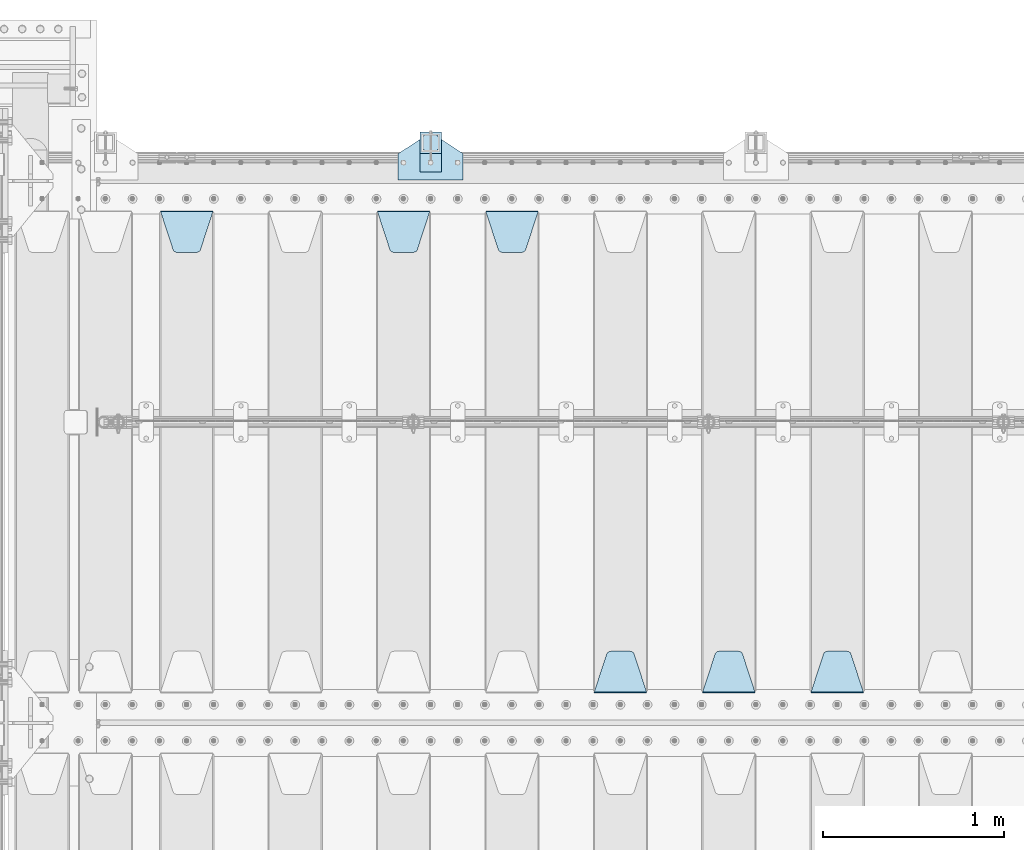
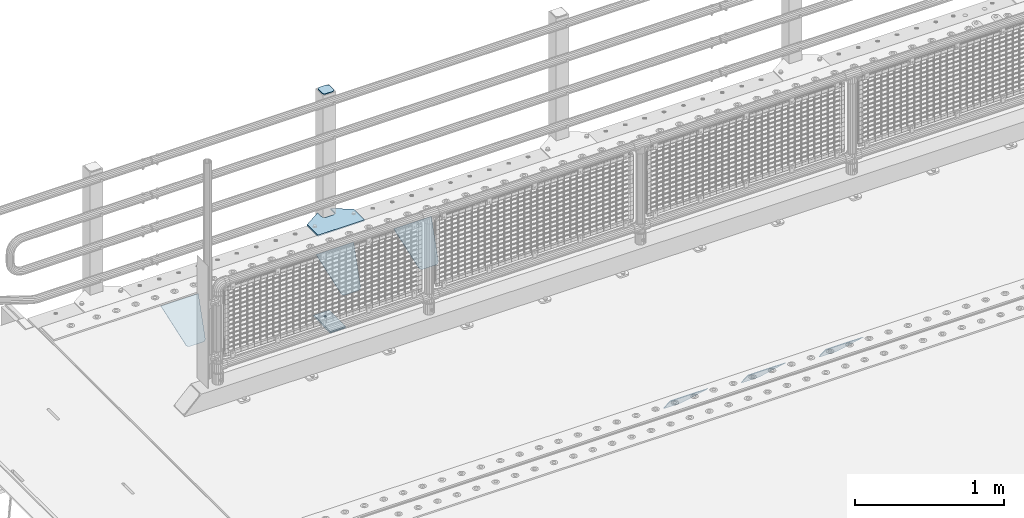
# One storey, part 201 of 242: 10 plates.
"""IFC2X3 building model written with IfcOpenShell, lengths in millimetres."""

from ifc_helpers import new_model, si_unit, frame, origin_with_axes, place, context, subcontext, project, spatial, faceted_brep, material, type_object, element, save


model = new_model("IFC2X3")

# Units and contexts
model_context = context("Model", 3, precision=1e-05, world=origin_with_axes())
body_context = subcontext(model_context, "Body", "Model", "MODEL_VIEW")
ifc_project = project(units=[si_unit("LENGTHUNIT", "METRE", prefix="MILLI"), si_unit("AREAUNIT", "SQUARE_METRE"), si_unit("VOLUMEUNIT", "CUBIC_METRE"), si_unit("MASSUNIT", "GRAM", prefix="KILO"), si_unit("TIMEUNIT", "SECOND"), si_unit("PLANEANGLEUNIT", "RADIAN"), si_unit("SOLIDANGLEUNIT", "STERADIAN"), si_unit("THERMODYNAMICTEMPERATUREUNIT", "DEGREE_CELSIUS"), si_unit("LUMINOUSINTENSITYUNIT", "LUMEN")], contexts=[model_context])

# Site, building, storey
site_placement = place(None, origin_with_axes())
site = spatial("IfcSite", under=ifc_project, at=site_placement, CompositionType="ELEMENT")
building_placement = place(site_placement, origin_with_axes())
building = spatial("IfcBuilding", under=site, at=building_placement, Name="Standard", CompositionType="ELEMENT")
storey_placement = place(building_placement, origin_with_axes())
storey = spatial("IfcBuildingStorey", under=building, at=storey_placement, Name="Undefined", CompositionType="ELEMENT", Elevation=0.0)

# Plates
ifc_material_1 = material(Name="STEEL/S355J2")
plate_type_1 = type_object("IfcPlateType", PredefinedType="NOTDEFINED")
plate_1_placement = place(storey_placement, frame((-40280.0, -17995.0, 5.00000000004911), z_axis=(0.0, 1.0, 0.0), x_axis=(1.0, 0.0, 0.0)))
element("IfcPlate", 1, at=plate_1_placement, inside=storey, type_object=plate_type_1, material=ifc_material_1, context=body_context, shape_type="Brep", body=[
    faceted_brep([(0.0, -5.0, 0.0), (2.31396552408114e-06, -5.0, 145.0), (2.31396552408114e-06, 5.0, 145.0), (0.0, 5.0, 0.0), (130.0, -5.0, 230.0), (130.0, 5.0, 230.0), (130.0, -5.0, 180.0), (130.0, 5.0, 180.0), (130.48036798992, -5.0, 175.122741949595), (130.48036798992, 5.0, 175.122741949595), (131.903011687216, -5.0, 170.432914190871), (131.903011687216, 5.0, 170.432914190871), (134.213259692435, -5.0, 166.110744174512), (134.213259692435, 5.0, 166.110744174512), (137.322330470335, -5.0, 162.322330470335), (137.322330470335, 5.0, 162.322330470335), (141.110744174512, -5.0, 159.213259692435), (141.110744174512, 5.0, 159.213259692435), (145.432914190871, -5.0, 156.903011687216), (145.432914190871, 5.0, 156.903011687216), (150.122741949595, -5.0, 155.48036798992), (150.122741949595, 5.0, 155.48036798992), (155.0, -5.0, 155.0), (155.0, 5.0, 155.0), (205.0, -5.0, 155.0), (205.0, 5.0, 155.0), (209.877258050405, -5.0, 155.48036798992), (209.877258050405, 5.0, 155.48036798992), (214.567085809129, -5.0, 156.903011687216), (214.567085809129, 5.0, 156.903011687216), (218.889255825488, -5.0, 159.213259692435), (218.889255825488, 5.0, 159.213259692435), (222.677669529665, -5.0, 162.322330470335), (222.677669529665, 5.0, 162.322330470335), (225.786740307565, -5.0, 166.110744174512), (225.786740307565, 5.0, 166.110744174512), (228.096988312784, -5.0, 170.432914190871), (228.096988312784, 5.0, 170.432914190871), (229.51963201008, -5.0, 175.122741949595), (229.51963201008, 5.0, 175.122741949595), (230.0, -5.0, 180.0), (230.0, 5.0, 180.0), (230.0, -5.0, 230.0), (230.0, 5.0, 230.0), (360.0, -5.0, 145.0), (360.0, 5.0, 145.0), (360.0, -5.0, -7.27595761418343e-12), (360.0, 5.0, -7.27595761418343e-12)], [[[0, 1, 2, 3]], [[1, 4, 5, 2]], [[4, 6, 7, 5]], [[6, 8, 9, 7]], [[8, 10, 11, 9]], [[10, 12, 13, 11]], [[12, 14, 15, 13]], [[14, 16, 17, 15]], [[16, 18, 19, 17]], [[18, 20, 21, 19]], [[20, 22, 23, 21]], [[22, 24, 25, 23]], [[24, 26, 27, 25]], [[26, 28, 29, 27]], [[28, 30, 31, 29]], [[30, 32, 33, 31]], [[32, 34, 35, 33]], [[34, 36, 37, 35]], [[36, 38, 39, 37]], [[38, 40, 41, 39]], [[40, 42, 43, 41]], [[42, 44, 45, 43]], [[44, 46, 47, 45]], [[46, 0, 3, 47]], [[5, 7, 9, 11, 13, 15, 17, 19, 21, 23, 25, 27, 29, 31, 33, 35, 37, 39, 41, 43, 45, 47, 3, 2]], [[46, 44, 42, 40, 38, 36, 34, 32, 30, 28, 26, 24, 22, 20, 18, 16, 14, 12, 10, 8, 6, 4, 1, 0]]]),
])
plate_type_2 = type_object("IfcPlateType", PredefinedType="NOTDEFINED")
plate_2_placement = place(storey_placement, frame((-40159.9999999999, -17949.9999999998, -850.000000000002), z_axis=(0.0, 1.0, 0.0), x_axis=(1.0, 0.0, 0.0)))
element("IfcPlate", 2, at=plate_2_placement, inside=storey, type_object=plate_type_2, material=ifc_material_1, context=body_context, shape_type="Brep", body=[
    faceted_brep([(66.3639610305399, -5.0, 163.636038969114), (66.3639610305399, 5.0, 163.636038969114), (59.9999999998618, 5.0, 160.999999999793), (59.9999999998618, -5.0, 160.999999999793), (53.6360389691836, 5.0, 163.636038969114), (53.6360389691836, -5.0, 163.636038969114), (50.9999999998618, 5.0, 169.999999999793), (50.9999999998618, -5.0, 169.999999999793), (53.6360389691836, 5.0, 176.363961030471), (53.6360389691836, -5.0, 176.363961030471), (59.9999999998618, 5.0, 178.999999999793), (59.9999999998618, -5.0, 178.999999999793), (66.3639610305399, 5.0, 176.363961030471), (66.3639610305399, -5.0, 176.363961030471), (68.9999999998618, 5.0, 169.999999999793), (68.9999999998618, -5.0, 169.999999999793), (120.0, -5.0, 0.0), (120.0, -5.0, 220.0), (0.0, -5.0, 220.0), (0.0, -5.0, 0.0), (0.0, 5.0, 0.0), (120.0, 5.0, 0.0), (120.0, 5.0, 220.0), (0.0, 5.0, 220.0)], [[[0, 1, 2, 3]], [[3, 2, 4, 5]], [[5, 4, 6, 7]], [[7, 6, 8, 9]], [[9, 8, 10, 11]], [[11, 10, 12, 13]], [[13, 12, 14, 15]], [[15, 14, 1, 0]], [[16, 17, 18, 19], [11, 13, 15, 0, 3, 5, 7, 9]], [[16, 19, 20, 21]], [[17, 16, 21, 22]], [[18, 17, 22, 23]], [[19, 18, 23, 20]], [[22, 21, 20, 23], [2, 1, 14, 12, 10, 8, 6, 4]]]),
])
plate_type_3 = type_object("IfcPlateType", PredefinedType="NOTDEFINED")
plate_3_placement = place(storey_placement, frame((-40055.9999999999, -17833.9999999998, 1012.50000000001), z_axis=(0.0, 1.0, 0.0), x_axis=(-1.0, 0.0, 0.0)))
element("IfcPlate", 3, at=plate_3_placement, inside=storey, type_object=plate_type_3, material=ifc_material_1, context=body_context, shape_type="Brep", body=[
    faceted_brep([(0.0, -2.5, 19.0), (0.0, -2.5, 69.0), (0.0, 2.5, 69.0), (0.0, 2.5, 19.0), (0.476369668544066, -2.5, 73.2278977451715), (0.476369668544066, 2.5, 73.2278977451715), (1.88159150985302, -2.5, 77.2437910432345), (1.88159150985302, 2.5, 77.2437910432345), (4.14520183310742, -2.5, 80.8463062353148), (4.14520183310742, 2.5, 80.8463062353148), (7.15369376468516, -2.5, 83.8547981668926), (7.15369376468516, 2.5, 83.8547981668926), (10.7562089567655, -2.5, 86.118408490147), (10.7562089567655, 2.5, 86.118408490147), (14.7721022548285, -2.5, 87.5236303314559), (14.7721022548285, 2.5, 87.5236303314559), (19.0, -2.5, 88.0), (19.0, 2.5, 88.0), (69.0, -2.5, 88.0), (69.0, 2.5, 88.0), (73.2278977451715, -2.5, 87.5236303314559), (73.2278977451715, 2.5, 87.5236303314559), (77.2437910432345, -2.5, 86.118408490147), (77.2437910432345, 2.5, 86.118408490147), (80.8463062353148, -2.5, 83.8547981668926), (80.8463062353148, 2.5, 83.8547981668926), (83.8547981668926, -2.5, 80.8463062353148), (83.8547981668926, 2.5, 80.8463062353148), (86.118408490147, -2.5, 77.2437910432345), (86.118408490147, 2.5, 77.2437910432345), (87.5236303314559, -2.5, 73.2278977451715), (87.5236303314559, 2.5, 73.2278977451715), (88.0, -2.5, 69.0), (88.0, 2.5, 69.0), (88.0, -2.5, 19.0), (88.0, 2.5, 19.0), (87.5236303314559, -2.5, 14.7721022548285), (87.5236303314559, 2.5, 14.7721022548285), (86.118408490147, -2.5, 10.7562089567655), (86.118408490147, 2.5, 10.7562089567655), (83.8547981668926, -2.5, 7.15369376468516), (83.8547981668926, 2.5, 7.15369376468516), (80.8463062353148, -2.5, 4.14520183310742), (80.8463062353148, 2.5, 4.14520183310742), (77.2437910432345, -2.5, 1.88159150985302), (77.2437910432345, 2.5, 1.88159150985302), (73.2278977451715, -2.5, 0.476369668544066), (73.2278977451715, 2.5, 0.476369668544066), (69.0, -2.5, 0.0), (69.0, 2.5, 0.0), (19.0, -2.5, 0.0), (19.0, 2.5, 0.0), (14.7721022548285, -2.5, 0.476369668544066), (14.7721022548285, 2.5, 0.476369668544066), (10.7562089567655, -2.5, 1.88159150985302), (10.7562089567655, 2.5, 1.88159150985302), (7.15369376468516, -2.5, 4.14520183310742), (7.15369376468516, 2.5, 4.14520183310742), (4.14520183310742, -2.5, 7.15369376468516), (4.14520183310742, 2.5, 7.15369376468516), (1.88159150985302, -2.5, 10.7562089567655), (1.88159150985302, 2.5, 10.7562089567655), (0.476369668544066, -2.5, 14.7721022548285), (0.476369668544066, 2.5, 14.7721022548285)], [[[0, 1, 2, 3]], [[1, 4, 5, 2]], [[4, 6, 7, 5]], [[6, 8, 9, 7]], [[8, 10, 11, 9]], [[10, 12, 13, 11]], [[12, 14, 15, 13]], [[14, 16, 17, 15]], [[16, 18, 19, 17]], [[18, 20, 21, 19]], [[20, 22, 23, 21]], [[22, 24, 25, 23]], [[24, 26, 27, 25]], [[26, 28, 29, 27]], [[28, 30, 31, 29]], [[30, 32, 33, 31]], [[32, 34, 35, 33]], [[34, 36, 37, 35]], [[36, 38, 39, 37]], [[38, 40, 41, 39]], [[40, 42, 43, 41]], [[42, 44, 45, 43]], [[44, 46, 47, 45]], [[46, 48, 49, 47]], [[48, 50, 51, 49]], [[50, 52, 53, 51]], [[52, 54, 55, 53]], [[54, 56, 57, 55]], [[56, 58, 59, 57]], [[58, 60, 61, 59]], [[60, 62, 63, 61]], [[62, 0, 3, 63]], [[5, 7, 9, 11, 13, 15, 17, 19, 21, 23, 25, 27, 29, 31, 33, 35, 37, 39, 41, 43, 45, 47, 49, 51, 53, 55, 57, 59, 61, 63, 3, 2]], [[62, 60, 58, 56, 54, 52, 50, 48, 46, 44, 42, 40, 38, 36, 34, 32, 30, 28, 26, 24, 22, 20, 18, 16, 14, 12, 10, 8, 6, 4, 1, 0]]]),
])
plate_type_4 = type_object("IfcPlateType", PredefinedType="NOTDEFINED")
plate_4_placement = place(storey_placement, frame((-40159.9999999999, -17949.9999999998, -857.500000000002), z_axis=(0.0, 1.0, 0.0), x_axis=(1.0, 0.0, 0.0)))
element("IfcPlate", 4, at=plate_4_placement, inside=storey, type_object=plate_type_4, material=ifc_material_1, context=body_context, shape_type="Brep", body=[
    faceted_brep([(0.0, -2.5, 0.0), (0.0, -2.5, 100.0), (0.0, 2.5, 100.0), (0.0, 2.5, 0.0), (120.0, -2.5, 100.0), (120.0, 2.5, 100.0), (120.0, -2.5, 0.0), (120.0, 2.5, 0.0)], [[[0, 1, 2, 3]], [[1, 4, 5, 2]], [[4, 6, 7, 5]], [[6, 0, 3, 7]], [[5, 7, 3, 2]], [[6, 4, 1, 0]]]),
])
ifc_material_2 = material(Name="STEEL/S355N")
plate_type_5 = type_object("IfcPlateType", PredefinedType="NOTDEFINED")
plate_5_placement = place(storey_placement, frame((-37705.0, -20831.767766953, -1.76776695296758), z_axis=(0.0, 0.707106781186547, -0.707106781186548), x_axis=(-1.0, 0.0, 0.0)))
element("IfcPlate", 5, at=plate_5_placement, inside=storey, type_object=plate_type_5, material=ifc_material_2, context=body_context, shape_type="Brep", body=[
    faceted_brep([(0.0, -2.5, 0.0), (69.345504679477, -2.50000000000182, 300.171731424829), (69.345504679477, 2.5, 300.171731424829), (0.0, 2.5, 0.0), (70.9274061199576, -2.5, 304.897442415398), (70.9274061199576, 2.5, 304.897442415398), (73.3818627772307, -2.5, 309.234538108525), (73.3818627772307, 2.50000000000182, 309.234538108529), (76.6187032999551, -2.5, 313.023683126101), (76.6187032999551, 2.50000000000182, 313.023683126103), (80.5190132704993, -2.5, 316.12567259537), (80.5190132704993, 2.5, 316.12567259537), (84.9395038596849, -2.5, 318.426546230474), (84.9395038596849, 2.50000000000182, 318.426546230476), (89.7177759439219, -2.49999999999818, 319.841774983273), (89.7177759439219, 2.50000000000182, 319.841774983273), (94.678286292652, -2.5, 320.319366455076), (94.678286292652, 2.5, 320.319366455076), (195.321713707348, -2.5, 320.319366455076), (195.321713707348, 2.5, 320.319366455076), (200.282224056078, -2.5, 319.841774983272), (200.282224056078, 2.50000000000182, 319.841774983273), (205.060496140315, -2.5, 318.426546230474), (205.060496140315, 2.49999999999818, 318.426546230474), (209.480986729501, -2.49999999999818, 316.12567259537), (209.480986729501, 2.5, 316.12567259537), (213.381296700045, -2.5, 313.023683126101), (213.381296700045, 2.49999999999818, 313.023683126101), (216.618137222769, -2.5, 309.234538108525), (216.618137222769, 2.5, 309.234538108523), (219.072593880042, -2.49999999999818, 304.897442415398), (219.072593880042, 2.50000000000182, 304.897442415398), (220.654495320523, -2.50000000000182, 300.171731424829), (220.654495320523, 2.5, 300.171731424829), (290.0, -2.5, 0.0), (290.0, 2.5, -1.81898940354586e-12)], [[[0, 1, 2, 3]], [[1, 4, 5, 2]], [[4, 6, 7, 5]], [[6, 8, 9, 7]], [[8, 10, 11, 9]], [[10, 12, 13, 11]], [[12, 14, 15, 13]], [[14, 16, 17, 15]], [[16, 18, 19, 17]], [[18, 20, 21, 19]], [[20, 22, 23, 21]], [[22, 24, 25, 23]], [[24, 26, 27, 25]], [[26, 28, 29, 27]], [[28, 30, 31, 29]], [[30, 32, 33, 31]], [[32, 34, 35, 33]], [[34, 0, 3, 35]], [[5, 7, 9, 11, 13, 15, 17, 19, 21, 23, 25, 27, 29, 31, 33, 35, 3, 2]], [[34, 32, 30, 28, 26, 24, 22, 20, 18, 16, 14, 12, 10, 8, 6, 4, 1, 0]]]),
])
plate_6_placement = place(storey_placement, frame((-38305.0, -20831.767766953, -1.76776695296758), z_axis=(0.0, 0.707106781186547, -0.707106781186548), x_axis=(-1.0, 0.0, 0.0)))
element("IfcPlate", 6, at=plate_6_placement, inside=storey, type_object=plate_type_5, material=ifc_material_2, context=body_context, shape_type="Brep", body=[
    faceted_brep([(0.0, -2.5, 0.0), (69.345504679477, -2.50000000000182, 300.171731424829), (69.345504679477, 2.5, 300.171731424829), (0.0, 2.5, 0.0), (70.9274061199576, -2.5, 304.897442415398), (70.9274061199576, 2.5, 304.897442415398), (73.3818627772307, -2.5, 309.234538108525), (73.3818627772307, 2.50000000000182, 309.234538108529), (76.6187032999551, -2.5, 313.023683126101), (76.6187032999551, 2.50000000000182, 313.023683126103), (80.5190132704993, -2.5, 316.12567259537), (80.5190132704993, 2.5, 316.12567259537), (84.9395038596849, -2.5, 318.426546230474), (84.9395038596849, 2.50000000000182, 318.426546230476), (89.7177759439219, -2.49999999999818, 319.841774983273), (89.7177759439219, 2.50000000000182, 319.841774983273), (94.678286292652, -2.5, 320.319366455076), (94.678286292652, 2.5, 320.319366455076), (195.321713707348, -2.5, 320.319366455076), (195.321713707348, 2.5, 320.319366455076), (200.282224056078, -2.5, 319.841774983272), (200.282224056078, 2.50000000000182, 319.841774983273), (205.060496140315, -2.5, 318.426546230474), (205.060496140315, 2.49999999999818, 318.426546230474), (209.480986729501, -2.49999999999818, 316.12567259537), (209.480986729501, 2.5, 316.12567259537), (213.381296700045, -2.5, 313.023683126101), (213.381296700045, 2.49999999999818, 313.023683126101), (216.618137222769, -2.5, 309.234538108525), (216.618137222769, 2.5, 309.234538108523), (219.072593880042, -2.49999999999818, 304.897442415398), (219.072593880042, 2.50000000000182, 304.897442415398), (220.654495320523, -2.50000000000182, 300.171731424829), (220.654495320523, 2.5, 300.171731424829), (290.0, -2.5, 0.0), (290.0, 2.5, -1.81898940354586e-12)], [[[0, 1, 2, 3]], [[1, 4, 5, 2]], [[4, 6, 7, 5]], [[6, 8, 9, 7]], [[8, 10, 11, 9]], [[10, 12, 13, 11]], [[12, 14, 15, 13]], [[14, 16, 17, 15]], [[16, 18, 19, 17]], [[18, 20, 21, 19]], [[20, 22, 23, 21]], [[22, 24, 25, 23]], [[24, 26, 27, 25]], [[26, 28, 29, 27]], [[28, 30, 31, 29]], [[30, 32, 33, 31]], [[32, 34, 35, 33]], [[34, 0, 3, 35]], [[5, 7, 9, 11, 13, 15, 17, 19, 21, 23, 25, 27, 29, 31, 33, 35, 3, 2]], [[34, 32, 30, 28, 26, 24, 22, 20, 18, 16, 14, 12, 10, 8, 6, 4, 1, 0]]]),
])
plate_7_placement = place(storey_placement, frame((-38905.0, -20831.767766953, -1.76776695296758), z_axis=(0.0, 0.707106781186547, -0.707106781186548), x_axis=(-1.0, 0.0, 0.0)))
element("IfcPlate", 7, at=plate_7_placement, inside=storey, type_object=plate_type_5, material=ifc_material_2, context=body_context, shape_type="Brep", body=[
    faceted_brep([(0.0, -2.5, 0.0), (69.345504679477, -2.50000000000182, 300.171731424829), (69.345504679477, 2.5, 300.171731424829), (0.0, 2.5, 0.0), (70.9274061199576, -2.5, 304.897442415398), (70.9274061199576, 2.5, 304.897442415398), (73.3818627772307, -2.5, 309.234538108525), (73.3818627772307, 2.50000000000182, 309.234538108529), (76.6187032999551, -2.5, 313.023683126101), (76.6187032999551, 2.50000000000182, 313.023683126103), (80.5190132704993, -2.5, 316.12567259537), (80.5190132704993, 2.5, 316.12567259537), (84.9395038596849, -2.5, 318.426546230474), (84.9395038596849, 2.50000000000182, 318.426546230476), (89.7177759439219, -2.49999999999818, 319.841774983273), (89.7177759439219, 2.50000000000182, 319.841774983273), (94.678286292652, -2.5, 320.319366455076), (94.678286292652, 2.5, 320.319366455076), (195.321713707348, -2.5, 320.319366455076), (195.321713707348, 2.5, 320.319366455076), (200.282224056078, -2.5, 319.841774983272), (200.282224056078, 2.50000000000182, 319.841774983273), (205.060496140315, -2.5, 318.426546230474), (205.060496140315, 2.49999999999818, 318.426546230474), (209.480986729501, -2.49999999999818, 316.12567259537), (209.480986729501, 2.5, 316.12567259537), (213.381296700045, -2.5, 313.023683126101), (213.381296700045, 2.49999999999818, 313.023683126101), (216.618137222769, -2.5, 309.234538108525), (216.618137222769, 2.5, 309.234538108523), (219.072593880042, -2.49999999999818, 304.897442415398), (219.072593880042, 2.50000000000182, 304.897442415398), (220.654495320523, -2.50000000000182, 300.171731424829), (220.654495320523, 2.5, 300.171731424829), (290.0, -2.5, 0.0), (290.0, 2.5, -1.81898940354586e-12)], [[[0, 1, 2, 3]], [[1, 4, 5, 2]], [[4, 6, 7, 5]], [[6, 8, 9, 7]], [[8, 10, 11, 9]], [[10, 12, 13, 11]], [[12, 14, 15, 13]], [[14, 16, 17, 15]], [[16, 18, 19, 17]], [[18, 20, 21, 19]], [[20, 22, 23, 21]], [[22, 24, 25, 23]], [[24, 26, 27, 25]], [[26, 28, 29, 27]], [[28, 30, 31, 29]], [[30, 32, 33, 31]], [[32, 34, 35, 33]], [[34, 0, 3, 35]], [[5, 7, 9, 11, 13, 15, 17, 19, 21, 23, 25, 27, 29, 31, 33, 35, 3, 2]], [[34, 32, 30, 28, 26, 24, 22, 20, 18, 16, 14, 12, 10, 8, 6, 4, 1, 0]]]),
])
plate_8_placement = place(storey_placement, frame((-39795.0, -18168.2322330441, -1.76776695296576), z_axis=(0.0, -0.707106781186547, -0.707106781186548), x_axis=(1.0, 0.0, 0.0)))
element("IfcPlate", 8, at=plate_8_placement, inside=storey, type_object=plate_type_5, material=ifc_material_2, context=body_context, shape_type="Brep", body=[
    faceted_brep([(0.0, -2.5, 0.0), (69.345504679477, -2.50000000000182, 300.171731424829), (69.345504679477, 2.5, 300.171731424829), (0.0, 2.5, 0.0), (70.9274061199576, -2.5, 304.897442415398), (70.9274061199576, 2.5, 304.897442415398), (73.3818627772307, -2.5, 309.234538108525), (73.3818627772307, 2.50000000000182, 309.234538108529), (76.6187032999551, -2.5, 313.023683126101), (76.6187032999551, 2.50000000000182, 313.023683126103), (80.5190132704993, -2.5, 316.12567259537), (80.5190132704993, 2.5, 316.12567259537), (84.9395038596849, -2.5, 318.426546230474), (84.9395038596849, 2.50000000000182, 318.426546230476), (89.7177759439219, -2.49999999999818, 319.841774983273), (89.7177759439219, 2.50000000000182, 319.841774983273), (94.678286292652, -2.5, 320.319366455076), (94.678286292652, 2.5, 320.319366455076), (195.321713707348, -2.5, 320.319366455076), (195.321713707348, 2.5, 320.319366455076), (200.282224056078, -2.5, 319.841774983272), (200.282224056078, 2.50000000000182, 319.841774983273), (205.060496140315, -2.5, 318.426546230474), (205.060496140315, 2.49999999999818, 318.426546230474), (209.480986729501, -2.49999999999818, 316.12567259537), (209.480986729501, 2.5, 316.12567259537), (213.381296700045, -2.5, 313.023683126101), (213.381296700045, 2.49999999999818, 313.023683126101), (216.618137222769, -2.5, 309.234538108525), (216.618137222769, 2.5, 309.234538108523), (219.072593880042, -2.49999999999818, 304.897442415398), (219.072593880042, 2.50000000000182, 304.897442415398), (220.654495320523, -2.50000000000182, 300.171731424829), (220.654495320523, 2.5, 300.171731424829), (290.0, -2.5, 0.0), (290.0, 2.5, -1.81898940354586e-12)], [[[0, 1, 2, 3]], [[1, 4, 5, 2]], [[4, 6, 7, 5]], [[6, 8, 9, 7]], [[8, 10, 11, 9]], [[10, 12, 13, 11]], [[12, 14, 15, 13]], [[14, 16, 17, 15]], [[16, 18, 19, 17]], [[18, 20, 21, 19]], [[20, 22, 23, 21]], [[22, 24, 25, 23]], [[24, 26, 27, 25]], [[26, 28, 29, 27]], [[28, 30, 31, 29]], [[30, 32, 33, 31]], [[32, 34, 35, 33]], [[34, 0, 3, 35]], [[5, 7, 9, 11, 13, 15, 17, 19, 21, 23, 25, 27, 29, 31, 33, 35, 3, 2]], [[34, 32, 30, 28, 26, 24, 22, 20, 18, 16, 14, 12, 10, 8, 6, 4, 1, 0]]]),
])
plate_9_placement = place(storey_placement, frame((-40395.0, -18168.2322330441, -1.76776695296576), z_axis=(0.0, -0.707106781186547, -0.707106781186548), x_axis=(1.0, 0.0, 0.0)))
element("IfcPlate", 9, at=plate_9_placement, inside=storey, type_object=plate_type_5, material=ifc_material_2, context=body_context, shape_type="Brep", body=[
    faceted_brep([(0.0, -2.5, 0.0), (69.345504679477, -2.50000000000182, 300.171731424829), (69.345504679477, 2.5, 300.171731424829), (0.0, 2.5, 0.0), (70.9274061199576, -2.5, 304.897442415398), (70.9274061199576, 2.5, 304.897442415398), (73.3818627772307, -2.5, 309.234538108525), (73.3818627772307, 2.50000000000182, 309.234538108529), (76.6187032999551, -2.5, 313.023683126101), (76.6187032999551, 2.50000000000182, 313.023683126103), (80.5190132704993, -2.5, 316.12567259537), (80.5190132704993, 2.5, 316.12567259537), (84.9395038596849, -2.5, 318.426546230474), (84.9395038596849, 2.50000000000182, 318.426546230476), (89.7177759439219, -2.49999999999818, 319.841774983273), (89.7177759439219, 2.50000000000182, 319.841774983273), (94.678286292652, -2.5, 320.319366455076), (94.678286292652, 2.5, 320.319366455076), (195.321713707348, -2.5, 320.319366455076), (195.321713707348, 2.5, 320.319366455076), (200.282224056078, -2.5, 319.841774983272), (200.282224056078, 2.50000000000182, 319.841774983273), (205.060496140315, -2.5, 318.426546230474), (205.060496140315, 2.49999999999818, 318.426546230474), (209.480986729501, -2.49999999999818, 316.12567259537), (209.480986729501, 2.5, 316.12567259537), (213.381296700045, -2.5, 313.023683126101), (213.381296700045, 2.49999999999818, 313.023683126101), (216.618137222769, -2.5, 309.234538108525), (216.618137222769, 2.5, 309.234538108523), (219.072593880042, -2.49999999999818, 304.897442415398), (219.072593880042, 2.50000000000182, 304.897442415398), (220.654495320523, -2.50000000000182, 300.171731424829), (220.654495320523, 2.5, 300.171731424829), (290.0, -2.5, 0.0), (290.0, 2.5, -1.81898940354586e-12)], [[[0, 1, 2, 3]], [[1, 4, 5, 2]], [[4, 6, 7, 5]], [[6, 8, 9, 7]], [[8, 10, 11, 9]], [[10, 12, 13, 11]], [[12, 14, 15, 13]], [[14, 16, 17, 15]], [[16, 18, 19, 17]], [[18, 20, 21, 19]], [[20, 22, 23, 21]], [[22, 24, 25, 23]], [[24, 26, 27, 25]], [[26, 28, 29, 27]], [[28, 30, 31, 29]], [[30, 32, 33, 31]], [[32, 34, 35, 33]], [[34, 0, 3, 35]], [[5, 7, 9, 11, 13, 15, 17, 19, 21, 23, 25, 27, 29, 31, 33, 35, 3, 2]], [[34, 32, 30, 28, 26, 24, 22, 20, 18, 16, 14, 12, 10, 8, 6, 4, 1, 0]]]),
])
plate_10_placement = place(storey_placement, frame((-41595.0, -18168.2322330441, -1.76776695296576), z_axis=(0.0, -0.707106781186547, -0.707106781186548), x_axis=(1.0, 0.0, 0.0)))
element("IfcPlate", 10, at=plate_10_placement, inside=storey, type_object=plate_type_5, material=ifc_material_2, context=body_context, shape_type="Brep", body=[
    faceted_brep([(0.0, -2.5, 0.0), (69.345504679477, -2.50000000000182, 300.171731424829), (69.345504679477, 2.5, 300.171731424829), (0.0, 2.5, 0.0), (70.9274061199576, -2.5, 304.897442415398), (70.9274061199576, 2.5, 304.897442415398), (73.3818627772307, -2.5, 309.234538108525), (73.3818627772307, 2.50000000000182, 309.234538108529), (76.6187032999551, -2.5, 313.023683126101), (76.6187032999551, 2.50000000000182, 313.023683126103), (80.5190132704993, -2.5, 316.12567259537), (80.5190132704993, 2.5, 316.12567259537), (84.9395038596849, -2.5, 318.426546230474), (84.9395038596849, 2.50000000000182, 318.426546230476), (89.7177759439219, -2.49999999999818, 319.841774983273), (89.7177759439219, 2.50000000000182, 319.841774983273), (94.678286292652, -2.5, 320.319366455076), (94.678286292652, 2.5, 320.319366455076), (195.321713707348, -2.5, 320.319366455076), (195.321713707348, 2.5, 320.319366455076), (200.282224056078, -2.5, 319.841774983272), (200.282224056078, 2.50000000000182, 319.841774983273), (205.060496140315, -2.5, 318.426546230474), (205.060496140315, 2.49999999999818, 318.426546230474), (209.480986729501, -2.49999999999818, 316.12567259537), (209.480986729501, 2.5, 316.12567259537), (213.381296700045, -2.5, 313.023683126101), (213.381296700045, 2.49999999999818, 313.023683126101), (216.618137222769, -2.5, 309.234538108525), (216.618137222769, 2.5, 309.234538108523), (219.072593880042, -2.49999999999818, 304.897442415398), (219.072593880042, 2.50000000000182, 304.897442415398), (220.654495320523, -2.50000000000182, 300.171731424829), (220.654495320523, 2.5, 300.171731424829), (290.0, -2.5, 0.0), (290.0, 2.5, -1.81898940354586e-12)], [[[0, 1, 2, 3]], [[1, 4, 5, 2]], [[4, 6, 7, 5]], [[6, 8, 9, 7]], [[8, 10, 11, 9]], [[10, 12, 13, 11]], [[12, 14, 15, 13]], [[14, 16, 17, 15]], [[16, 18, 19, 17]], [[18, 20, 21, 19]], [[20, 22, 23, 21]], [[22, 24, 25, 23]], [[24, 26, 27, 25]], [[26, 28, 29, 27]], [[28, 30, 31, 29]], [[30, 32, 33, 31]], [[32, 34, 35, 33]], [[34, 0, 3, 35]], [[5, 7, 9, 11, 13, 15, 17, 19, 21, 23, 25, 27, 29, 31, 33, 35, 3, 2]], [[34, 32, 30, 28, 26, 24, 22, 20, 18, 16, 14, 12, 10, 8, 6, 4, 1, 0]]]),
])

save(model, "model.ifc")
